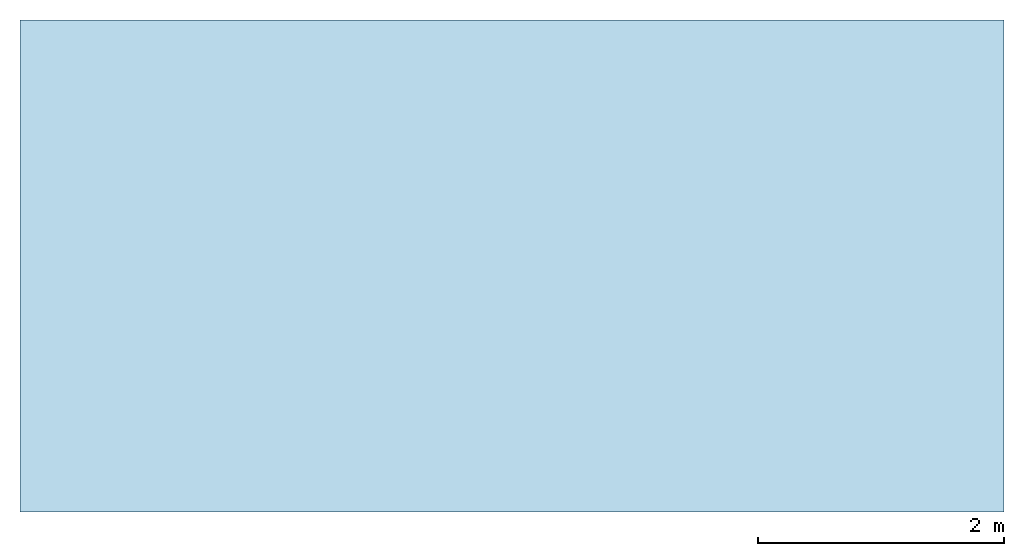
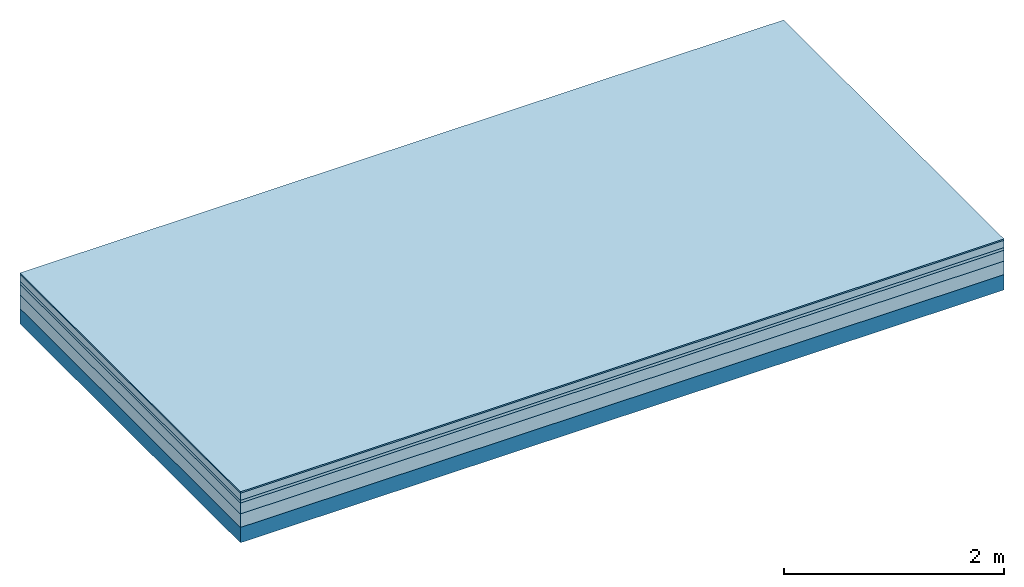
# One storey: 5 plates, 1 member, 1 element without a shape of its own.
"""IFC4 building model written with IfcOpenShell, lengths in metres."""

from ifc_helpers import new_model, si_unit, derived_unit, direction, frame, frame_2d, origin, origin_with_axes, place, context, project, spatial, rectangle, extrude, material, layer, layer_set, type_object, element, aggregate, save


model = new_model("IFC4")

# Units and contexts
plan_context = context("Plan", 3, precision=1e-05, world=origin(), true_north=direction((0.0, 1.0)))
model_context = context("Model", 3, precision=1e-05, world=origin(), true_north=direction((0.0, 1.0)))
ifc_project = project(units=[si_unit("LENGTHUNIT", "METRE"), derived_unit("SOUNDPRESSUREUNIT", [(si_unit("PRESSUREUNIT", "PASCAL", prefix="MICRO"), 0)]), si_unit("ENERGYUNIT", "JOULE", prefix="MEGA"), si_unit("MASSUNIT", "GRAM", prefix="KILO"), derived_unit("THERMALTRANSMITTANCEUNIT", [(si_unit("POWERUNIT", "WATT"), 1), (si_unit("AREAUNIT", "SQUARE_METRE"), -1), (si_unit("THERMODYNAMICTEMPERATUREUNIT", "KELVIN"), -1)]), derived_unit("AREADENSITYUNIT", [(si_unit("MASSUNIT", "GRAM", prefix="KILO"), 1), (si_unit("AREAUNIT", "SQUARE_METRE"), -1)]), derived_unit("USERDEFINED", [(si_unit("ENERGYUNIT", "JOULE", prefix="MEGA"), 1), (si_unit("AREAUNIT", "SQUARE_METRE"), -1)])], contexts=[plan_context, model_context])

# Site, building, storey
site = spatial("IfcSite", under=ifc_project)
building_placement = place(None, origin())
building = spatial("IfcBuilding", under=site, at=building_placement)
storey_placement = place(building_placement, origin())
storey = spatial("IfcBuildingStorey", under=building, at=storey_placement)

# Slab, member, plates
ifc_material_1 = material(Category="11.013")
ifc_layer_1 = layer(ifc_material_1, 0.015, Name="Flooring")
ifc_material_2 = material(Name="Cement screed", Category="04.006")
ifc_layer_2 = layer(ifc_material_2, 0.08, Name="On-material")
ifc_material_3 = material(Name="Wood fiber generic product", Category="10.009")
ifc_layer_3 = layer(ifc_material_3, 0.03, Name="Impact sound insulation")
ifc_material_4 = material(Name="Cement screed with EPS", Category="04.006")
ifc_layer_4 = layer(ifc_material_4, 0.12, Name="on Supporting structure")
ifc_material_5 = material(Category="01.002")
ifc_layer_5 = layer(ifc_material_5, 0.15, Name="Sub-floor")
ifc_material_6 = material(Name="Rigid, of the art")
ifc_layer_6 = layer(ifc_material_6, 0.0, Name="Bond")
ifc_layer_7 = layer(None, 0.17, Name="Supporting structure")
ifc_layer_set = layer_set([ifc_layer_1, ifc_layer_2, ifc_layer_3, ifc_layer_4, ifc_layer_5, ifc_layer_6, ifc_layer_7])
slab_type = type_object("IfcSlabType", Name="A2220", PredefinedType="NOTDEFINED", material=ifc_layer_set)
slab_placement = place(None, frame((0.0, 0.0, 0.0), z_axis=(0.0, 0.0, -1.0), x_axis=(1.0, 0.0, 0.0)))
slab = element("IfcSlab", 1, at=slab_placement, inside=storey, type_object=slab_type, material=ifc_layer_set, Name="Slab #1")
ifc_material_7 = material(Name="Solid timber panel")
member_placement = place(slab_placement, origin())
member = element("IfcMember", 2, at=member_placement, material=ifc_material_7, Name="Supporting structure", context=plan_context, shape_type="SweptSolid", body=[
    extrude(rectangle(XDim=1.0, YDim=0.17, at=frame_2d((0.5, 0.085), x_axis=(1.0, 0.0))), frame((0.0, 4.0, 0.395), z_axis=(0.0, -1.0, 0.0), x_axis=(1.0, 0.0, 0.0)), (0.0, 0.0, 1.0), 4.0),
    extrude(rectangle(XDim=1.0, YDim=0.17, at=frame_2d((0.5, 0.085), x_axis=(1.0, 0.0))), frame((1.0, 4.0, 0.395), z_axis=(0.0, -1.0, 0.0), x_axis=(1.0, 0.0, 0.0)), (0.0, 0.0, 1.0), 4.0),
    extrude(rectangle(XDim=1.0, YDim=0.17, at=frame_2d((0.5, 0.085), x_axis=(1.0, 0.0))), frame((2.0, 4.0, 0.395), z_axis=(0.0, -1.0, 0.0), x_axis=(1.0, 0.0, 0.0)), (0.0, 0.0, 1.0), 4.0),
    extrude(rectangle(XDim=1.0, YDim=0.17, at=frame_2d((0.5, 0.085), x_axis=(1.0, 0.0))), frame((3.0, 4.0, 0.395), z_axis=(0.0, -1.0, 0.0), x_axis=(1.0, 0.0, 0.0)), (0.0, 0.0, 1.0), 4.0),
    extrude(rectangle(XDim=1.0, YDim=0.17, at=frame_2d((0.5, 0.085), x_axis=(1.0, 0.0))), frame((4.0, 4.0, 0.395), z_axis=(0.0, -1.0, 0.0), x_axis=(1.0, 0.0, 0.0)), (0.0, 0.0, 1.0), 4.0),
    extrude(rectangle(XDim=1.0, YDim=0.17, at=frame_2d((0.5, 0.085), x_axis=(1.0, 0.0))), frame((5.0, 4.0, 0.395), z_axis=(0.0, -1.0, 0.0), x_axis=(1.0, 0.0, 0.0)), (0.0, 0.0, 1.0), 4.0),
    extrude(rectangle(XDim=1.0, YDim=0.17, at=frame_2d((0.5, 0.085), x_axis=(1.0, 0.0))), frame((6.0, 4.0, 0.395), z_axis=(0.0, -1.0, 0.0), x_axis=(1.0, 0.0, 0.0)), (0.0, 0.0, 1.0), 4.0),
    extrude(rectangle(XDim=1.0, YDim=0.17, at=frame_2d((0.5, 0.085), x_axis=(1.0, 0.0))), frame((7.0, 4.0, 0.395), z_axis=(0.0, -1.0, 0.0), x_axis=(1.0, 0.0, 0.0)), (0.0, 0.0, 1.0), 4.0),
])
plate_1_placement = place(slab_placement, origin())
plate_1 = element("IfcPlate", 3, at=plate_1_placement, material=ifc_material_1, Name="Flooring", context=plan_context, shape_type="SweptSolid", body=[
    extrude(rectangle(XDim=8.0, YDim=4.0, at=frame_2d((4.0, 2.0), x_axis=(1.0, 0.0))), origin_with_axes(), (0.0, 0.0, 1.0), 0.015),
])
plate_2_placement = place(slab_placement, origin())
plate_2 = element("IfcPlate", 4, at=plate_2_placement, material=ifc_material_2, Name="On-material", context=plan_context, shape_type="SweptSolid", body=[
    extrude(rectangle(XDim=8.0, YDim=4.0, at=frame_2d((4.0, 2.0), x_axis=(1.0, 0.0))), frame((0.0, 0.0, 0.015), z_axis=(0.0, 0.0, 1.0), x_axis=(1.0, 0.0, 0.0)), (0.0, 0.0, 1.0), 0.08),
])
plate_3_placement = place(slab_placement, origin())
plate_3 = element("IfcPlate", 5, at=plate_3_placement, material=ifc_material_3, Name="Impact sound insulation", context=plan_context, shape_type="SweptSolid", body=[
    extrude(rectangle(XDim=8.0, YDim=4.0, at=frame_2d((4.0, 2.0), x_axis=(1.0, 0.0))), frame((0.0, 0.0, 0.095), z_axis=(0.0, 0.0, 1.0), x_axis=(1.0, 0.0, 0.0)), (0.0, 0.0, 1.0), 0.03),
])
plate_4_placement = place(slab_placement, origin())
plate_4 = element("IfcPlate", 6, at=plate_4_placement, material=ifc_material_4, Name="on Supporting structure", context=plan_context, shape_type="SweptSolid", body=[
    extrude(rectangle(XDim=8.0, YDim=4.0, at=frame_2d((4.0, 2.0), x_axis=(1.0, 0.0))), frame((0.0, 0.0, 0.125), z_axis=(0.0, 0.0, 1.0), x_axis=(1.0, 0.0, 0.0)), (0.0, 0.0, 1.0), 0.12),
])
plate_5_placement = place(slab_placement, origin())
plate_5 = element("IfcPlate", 7, at=plate_5_placement, material=ifc_material_5, Name="Sub-floor", context=plan_context, shape_type="SweptSolid", body=[
    extrude(rectangle(XDim=8.0, YDim=4.0, at=frame_2d((4.0, 2.0), x_axis=(1.0, 0.0))), frame((0.0, 0.0, 0.245), z_axis=(0.0, 0.0, 1.0), x_axis=(1.0, 0.0, 0.0)), (0.0, 0.0, 1.0), 0.15),
])
aggregate(slab, [plate_1, plate_2, plate_3, plate_4, plate_5, member])

save(model, "model.ifc")
